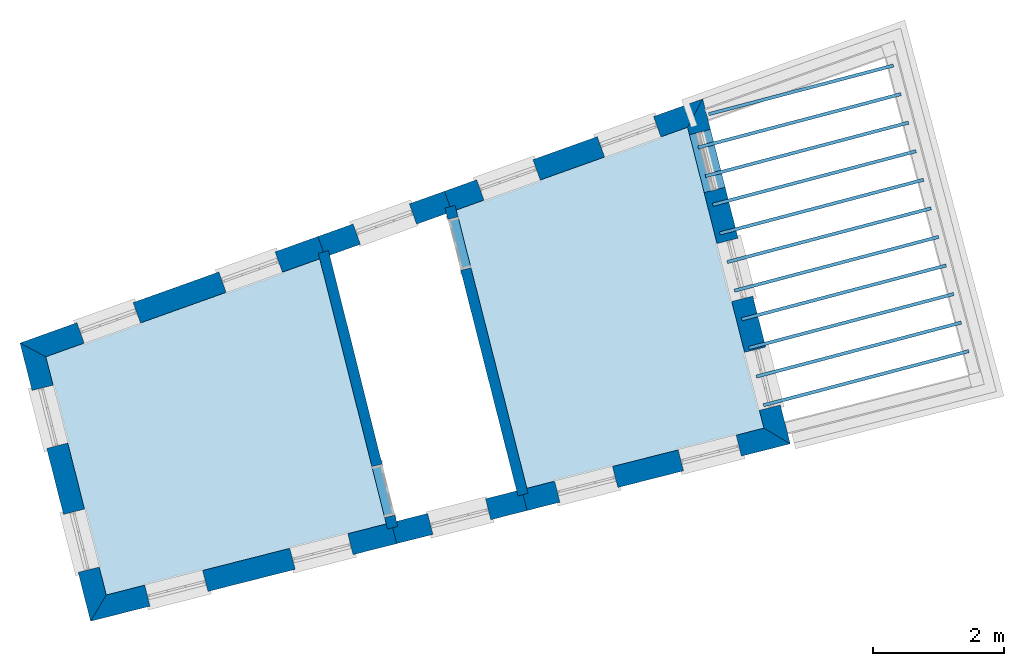
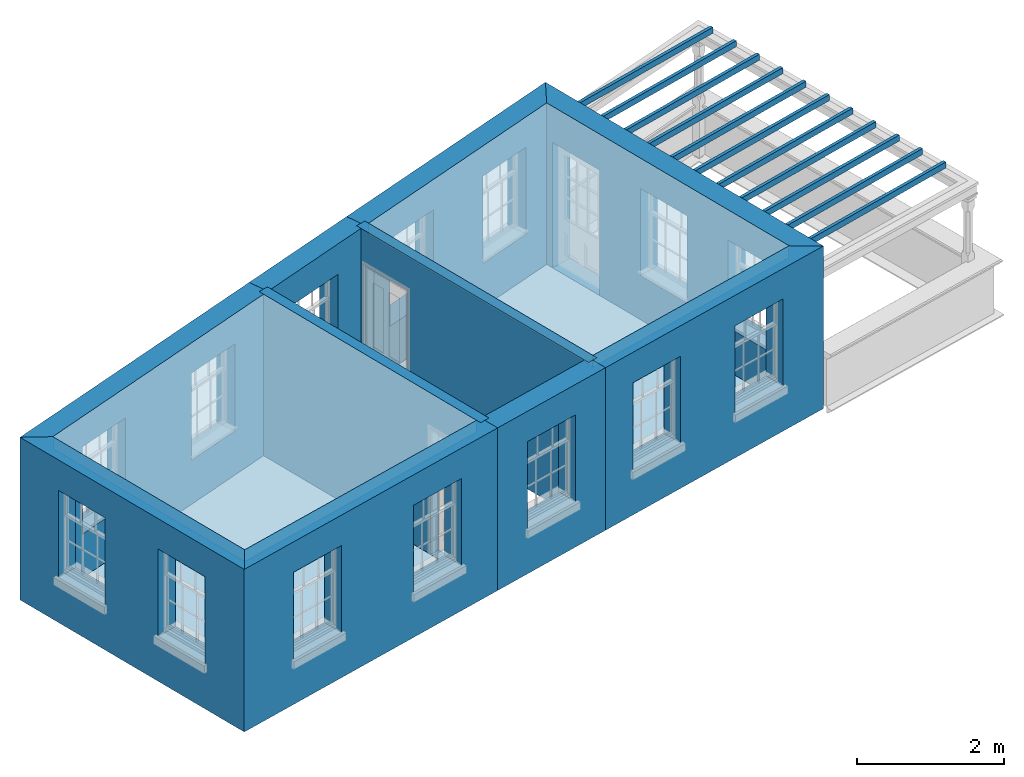
# One storey, part 1 of 10: 15 slabs, 10 walls, 17 openings.
"""IFC2X3 building model written with IfcOpenShell, lengths in metres."""

from ifc_helpers import new_model, si_unit, frame, origin, place, context, subcontext, project, spatial, polyline, outline, extrude, material, layer, layer_set, layer_usage, element, save


model = new_model("IFC2X3")

# Units and contexts
model_context = context("Model", 3, world=origin())
body_context = subcontext(model_context, "Body", "Model", "MODEL_VIEW")
ifc_project = project(units=[si_unit("PLANEANGLEUNIT", "RADIAN"), si_unit("MASSUNIT", "GRAM", prefix="KILO"), si_unit("FORCEUNIT", "NEWTON", prefix="KILO"), si_unit("LENGTHUNIT", "METRE")], contexts=[model_context])

# Site, building, storey
site_placement = place(None, origin())
site = spatial("IfcSite", under=ifc_project, at=site_placement, CompositionType="ELEMENT")
building_placement = place(None, origin())
building = spatial("IfcBuilding", under=site, at=building_placement, Name="Building plot-13", CompositionType="ELEMENT")
storey_placement = place(None, frame((0.0, 0.0, 9.55)))
storey = spatial("IfcBuildingStorey", under=building, at=storey_placement, Name="Floor 2", CompositionType="ELEMENT", Elevation=9.55)

# Slabs
slab_1_placement = place(storey_placement, frame((0.0, 0.0, 2.5)))
element("IfcSlab", 1, at=slab_1_placement, inside=storey, Name="Slab", ObjectType="Slab", PredefinedType="FLOOR", context=body_context, shape_type="SweptSolid", body=[
    extrude(outline(polyline([(72.1588295162765, 49.7758111334306), (73.2338394240791, 45.5372661691658), (76.8445718371103, 46.4530457942866), (75.6822868035305, 51.0356987915879), (72.1588295162765, 49.7758111334306)])), origin(), (0.0, 0.0, 1.0), 0.2),
])
slab_2_placement = place(storey_placement, frame((0.0, 0.0, 2.5)))
element("IfcSlab", 2, at=slab_2_placement, inside=storey, Name="Slab", ObjectType="Slab", PredefinedType="FLOOR", context=body_context, shape_type="SweptSolid", body=[
    extrude(outline(polyline([(66.8267058597151, 43.9122434030099), (71.0924235909926, 44.9941450611672), (70.0791346157294, 49.0321716554071), (65.9065629771408, 47.5401792508866), (66.8267058597151, 43.9122434030099)])), origin(), (0.0, 0.0, 1.0), 0.2),
])
slab_3_placement = place(storey_placement, frame((0.0, 0.0, 2.2)))
element("IfcSlab", 3, at=slab_3_placement, inside=storey, Name="Slab", ObjectType="Slab", PredefinedType="FLOOR", context=body_context, shape_type="SweptSolid", body=[
    extrude(outline(polyline([(79.9713806910682, 47.6019934885122), (79.9586352130492, 47.6503417334655), (76.8322302748347, 46.8261644451892), (76.8449757528537, 46.7778162002358), (79.9713806910682, 47.6019934885122)])), origin(), (0.0, 0.0, 1.0), 0.1),
])
slab_4_placement = place(storey_placement, frame((0.0, 0.0, 2.2)))
element("IfcSlab", 4, at=slab_4_placement, inside=storey, Name="Slab", ObjectType="Slab", PredefinedType="FLOOR", context=body_context, shape_type="SweptSolid", body=[
    extrude(outline(polyline([(79.856671388897, 48.0371276930921), (79.843925910878, 48.0854759380454), (76.7215959859344, 47.2623728974925), (76.7343414639534, 47.2140246525392), (79.856671388897, 48.0371276930921)])), origin(), (0.0, 0.0, 1.0), 0.1),
])
slab_5_placement = place(storey_placement, frame((0.0, 0.0, 2.2)))
element("IfcSlab", 5, at=slab_5_placement, inside=storey, Name="Slab", ObjectType="Slab", PredefinedType="FLOOR", context=body_context, shape_type="SweptSolid", body=[
    extrude(outline(polyline([(79.7419620867259, 48.472261897672), (79.7292166087069, 48.5206101426254), (76.6109616970342, 47.6985813497958), (76.6237071750532, 47.6502331048425), (79.7419620867259, 48.472261897672)])), origin(), (0.0, 0.0, 1.0), 0.1),
])
slab_6_placement = place(storey_placement, frame((0.0, 0.0, 2.2)))
element("IfcSlab", 6, at=slab_6_placement, inside=storey, Name="Slab", ObjectType="Slab", PredefinedType="FLOOR", context=body_context, shape_type="SweptSolid", body=[
    extrude(outline(polyline([(79.6272527845548, 48.907396102252), (79.6145073065358, 48.9557443472053), (76.5003274081339, 48.1347898020991), (76.5130728861529, 48.0864415571458), (79.6272527845548, 48.907396102252)])), origin(), (0.0, 0.0, 1.0), 0.1),
])
slab_7_placement = place(storey_placement, frame((0.0, 0.0, 2.2)))
element("IfcSlab", 7, at=slab_7_placement, inside=storey, Name="Slab", ObjectType="Slab", PredefinedType="FLOOR", context=body_context, shape_type="SweptSolid", body=[
    extrude(outline(polyline([(79.5125434823836, 49.3425303068319), (79.4997980043646, 49.3908785517852), (76.3896931192336, 48.5709982544025), (76.4024385972526, 48.5226500094491), (79.5125434823836, 49.3425303068319)])), origin(), (0.0, 0.0, 1.0), 0.1),
])
slab_8_placement = place(storey_placement, frame((0.0, 0.0, 2.2)))
element("IfcSlab", 8, at=slab_8_placement, inside=storey, Name="Slab", ObjectType="Slab", PredefinedType="FLOOR", context=body_context, shape_type="SweptSolid", body=[
    extrude(outline(polyline([(79.3978341802125, 49.7776645114118), (79.3850887021935, 49.8260127563652), (76.2790588303333, 49.0072067067058), (76.2918043083523, 48.9588584617524), (79.3978341802125, 49.7776645114118)])), origin(), (0.0, 0.0, 1.0), 0.1),
])
slab_9_placement = place(storey_placement, frame((0.0, 0.0, 2.2)))
element("IfcSlab", 9, at=slab_9_placement, inside=storey, Name="Slab", ObjectType="Slab", PredefinedType="FLOOR", context=body_context, shape_type="SweptSolid", body=[
    extrude(outline(polyline([(79.2831248780414, 50.2127987159918), (79.2703794000223, 50.2611469609451), (76.168424541433, 49.4434151590091), (76.1811700194521, 49.3950669140558), (79.2831248780414, 50.2127987159918)])), origin(), (0.0, 0.0, 1.0), 0.1),
])
slab_10_placement = place(storey_placement, frame((0.0, 0.0, 2.2)))
element("IfcSlab", 10, at=slab_10_placement, inside=storey, Name="Slab", ObjectType="Slab", PredefinedType="FLOOR", context=body_context, shape_type="SweptSolid", body=[
    extrude(outline(polyline([(79.1684155758702, 50.6479329205717), (79.1556700978512, 50.696281165525), (76.0577902525328, 49.8796236113124), (76.0705357305518, 49.8312753663591), (79.1684155758702, 50.6479329205717)])), origin(), (0.0, 0.0, 1.0), 0.1),
])
slab_11_placement = place(storey_placement, frame((0.0, 0.0, 2.2)))
element("IfcSlab", 11, at=slab_11_placement, inside=storey, Name="Slab", ObjectType="Slab", PredefinedType="FLOOR", context=body_context, shape_type="SweptSolid", body=[
    extrude(outline(polyline([(79.0537062736991, 51.0830671251516), (79.0409607956801, 51.131415370105), (75.9471559636325, 50.3158320636157), (75.9599014416515, 50.2674838186624), (79.0537062736991, 51.0830671251516)])), origin(), (0.0, 0.0, 1.0), 0.1),
])
slab_12_placement = place(storey_placement, frame((0.0, 0.0, 2.2)))
element("IfcSlab", 12, at=slab_12_placement, inside=storey, Name="Slab", ObjectType="Slab", PredefinedType="FLOOR", context=body_context, shape_type="SweptSolid", body=[
    extrude(outline(polyline([(78.938996971528, 51.5182013297316), (78.9262514935089, 51.5665495746849), (75.8365216747322, 50.7520405159191), (75.8492671527512, 50.7036922709657), (78.938996971528, 51.5182013297316)])), origin(), (0.0, 0.0, 1.0), 0.1),
])
slab_13_placement = place(storey_placement, frame((0.0, 0.0, 2.2)))
element("IfcSlab", 13, at=slab_13_placement, inside=storey, Name="Slab", ObjectType="Slab", PredefinedType="FLOOR", context=body_context, shape_type="SweptSolid", body=[
    extrude(outline(polyline([(78.8242876693568, 51.9533355343115), (78.8115421913378, 52.0016837792648), (75.9977942108907, 51.2599285600122), (76.0105396889098, 51.2115803150588), (78.8242876693568, 51.9533355343115)])), origin(), (0.0, 0.0, 1.0), 0.1),
])
slab_14_placement = place(storey_placement, origin())
element("IfcSlab", 14, at=slab_14_placement, inside=storey, Name="Slab", ObjectType="Slab", PredefinedType="FLOOR", context=body_context, shape_type="SweptSolid", body=[
    extrude(outline(polyline([(72.1588295162765, 49.7758111334306), (73.2338394240791, 45.5372661691658), (76.8445718371103, 46.4530457942866), (75.6822868035305, 51.0356987915879), (72.1588295162765, 49.7758111334306)])), origin(), (0.0, 0.0, 1.0), 0.02),
])
slab_15_placement = place(storey_placement, origin())
element("IfcSlab", 15, at=slab_15_placement, inside=storey, Name="Slab", ObjectType="Slab", PredefinedType="FLOOR", context=body_context, shape_type="SweptSolid", body=[
    extrude(outline(polyline([(66.8267058597151, 43.9122434030099), (71.0924235909926, 44.9941450611672), (70.0791346157294, 49.0321716554071), (65.9065629771408, 47.5401792508866), (66.8267058597151, 43.9122434030099)])), origin(), (0.0, 0.0, 1.0), 0.02),
])

# Wall, openings
ifc_material_1 = material(Name="Masonry")
ifc_layer_1 = layer(ifc_material_1, 0.33, ventilated=False)
ifc_layer_set_1 = layer_set([ifc_layer_1], Name="My Wall")
ifc_layer_usage_1 = layer_usage(ifc_layer_set_1, "AXIS2", "NEGATIVE", 0.08)
wall_1_placement = place(storey_placement, origin())
wall_1 = element("IfcWallStandardCase", 16, at=wall_1_placement, inside=storey, material=ifc_layer_usage_1, Name="exterior", context=body_context, shape_type="SweptSolid", body=[
    extrude(outline(polyline([(73.1562946551384, 45.5175987135619), (73.2374229095042, 45.1977265416814), (77.2455722633567, 46.2143018767719), (76.8445718371103, 46.4530457942866), (73.1562946551384, 45.5175987135619)])), origin(), (0.0, 0.0, 1.0), 2.7),
])
opening_1_placement = place(storey_placement, frame((0.0, 0.0, 0.75)))
element("IfcOpeningElement", 17, at=opening_1_placement, cuts=wall_1, Name="Opening", ObjectType="Opening", context=body_context, shape_type="SweptSolid", body=[
    extrude(outline(polyline([(73.737842523882, 45.3246465220167), (74.6199142705828, 45.5483638295104), (74.5387860162169, 45.8682360013909), (73.6567142695161, 45.6445186938972), (73.737842523882, 45.3246465220167)])), origin(), (0.0, 0.0, 1.0), 1.445),
])
opening_2_placement = place(storey_placement, frame((0.0, 0.0, 0.75)))
element("IfcOpeningElement", 18, at=opening_2_placement, cuts=wall_1, Name="Opening", ObjectType="Opening", context=body_context, shape_type="SweptSolid", body=[
    extrude(outline(polyline([(75.6207534993383, 45.802203790181), (76.5028252460391, 46.0259210976746), (76.4216969916733, 46.3457932695551), (75.5396252449725, 46.1220759620615), (75.6207534993383, 45.802203790181)])), origin(), (0.0, 0.0, 1.0), 1.445),
])

wall_2_placement = place(storey_placement, origin())
wall_2 = element("IfcWallStandardCase", 19, at=wall_2_placement, inside=storey, material=ifc_layer_usage_1, Name="exterior", context=body_context, shape_type="SweptSolid", body=[
    extrude(outline(polyline([(76.8445718371103, 46.4530457942866), (77.2455722633567, 46.2143018767719), (75.9129314952901, 51.4686328142499), (75.6822868035305, 51.0356987915879), (76.8445718371103, 46.4530457942866)])), origin(), (0.0, 0.0, 1.0), 2.7),
])
opening_3_placement = place(storey_placement, frame((0.0, 0.0, 0.75)))
element("IfcOpeningElement", 20, at=opening_3_placement, cuts=wall_2, Name="Opening", ObjectType="Opening", context=body_context, shape_type="SweptSolid", body=[
    extrude(outline(polyline([(77.0953728860989, 46.8065074085449), (76.8716555786053, 47.6885791552457), (76.5517834067248, 47.6074509008799), (76.7755007142184, 46.7253791541791), (77.0953728860989, 46.8065074085449)])), origin(), (0.0, 0.0, 1.0), 1.445),
])
opening_4_placement = place(storey_placement, frame((0.0, 0.0, 0.75)))
element("IfcOpeningElement", 21, at=opening_4_placement, cuts=wall_2, Name="Opening", ObjectType="Opening", context=body_context, shape_type="SweptSolid", body=[
    extrude(outline(polyline([(76.6749810225669, 48.464026844653), (76.4512637150733, 49.3460985913538), (76.1313915431928, 49.264970336988), (76.3551088506864, 48.3828985902872), (76.6749810225669, 48.464026844653)])), origin(), (0.0, 0.0, 1.0), 1.445),
])
opening_5_placement = place(storey_placement, frame((0.0, 0.0, 0.0199999999999996)))
element("IfcOpeningElement", 22, at=opening_5_placement, cuts=wall_2, Name="Opening", ObjectType="Opening", context=body_context, shape_type="SweptSolid", body=[
    extrude(outline(polyline([(76.2545891590349, 50.1215462807611), (76.0308718515412, 51.0036180274619), (75.7109996796607, 50.9224897730961), (75.9347169871544, 50.0404180263953), (76.2545891590349, 50.1215462807611)])), origin(), (0.0, 0.0, 1.0), 2.08),
])

wall_3_placement = place(storey_placement, origin())
wall_3 = element("IfcWallStandardCase", 23, at=wall_3_placement, inside=storey, material=ifc_layer_usage_1, Name="exterior", context=body_context, shape_type="SweptSolid", body=[
    extrude(outline(polyline([(75.6822868035305, 51.0356987915879), (75.9129314952901, 51.4686328142499), (71.9792289491637, 50.0620531725284), (72.090338058868, 49.7513205451126), (75.6822868035305, 51.0356987915879)])), origin(), (0.0, 0.0, 1.0), 2.7),
])
opening_6_placement = place(storey_placement, frame((0.0, 0.0, 0.75)))
element("IfcOpeningElement", 24, at=opening_6_placement, cuts=wall_3, Name="Opening", ObjectType="Opening", context=body_context, shape_type="SweptSolid", body=[
    extrude(outline(polyline([(75.163761942697, 51.2007511865675), (74.3068931822474, 50.894359399201), (74.4180022919517, 50.5836267717852), (75.2748710524013, 50.8900185591517), (75.163761942697, 51.2007511865675)])), origin(), (0.0, 0.0, 1.0), 1.445),
])
opening_7_placement = place(storey_placement, frame((0.0, 0.0, 0.75)))
element("IfcOpeningElement", 25, at=opening_7_placement, cuts=wall_3, Name="Opening", ObjectType="Opening", context=body_context, shape_type="SweptSolid", body=[
    extrude(outline(polyline([(73.326362867158, 50.5437497729969), (72.4694941067084, 50.2373579856305), (72.5806032164127, 49.9266253582147), (73.4374719768623, 50.2330171455811), (73.326362867158, 50.5437497729969)])), origin(), (0.0, 0.0, 1.0), 1.445),
])

# Wall, opening
wall_4_placement = place(storey_placement, origin())
wall_4 = element("IfcWallStandardCase", 26, at=wall_4_placement, inside=storey, material=ifc_layer_usage_1, Name="exterior", context=body_context, shape_type="SweptSolid", body=[
    extrude(outline(polyline([(72.090338058868, 49.7513205451126), (71.9792289491637, 50.0620531725284), (70.0510857180657, 49.3726042415572), (70.16219482777, 49.0618716141414), (72.090338058868, 49.7513205451126)])), origin(), (0.0, 0.0, 1.0), 2.7),
])
opening_8_placement = place(storey_placement, frame((0.0, 0.0, 0.75)))
element("IfcOpeningElement", 27, at=opening_8_placement, cuts=wall_4, Name="Opening", ObjectType="Opening", context=body_context, shape_type="SweptSolid", body=[
    extrude(outline(polyline([(71.4435917138395, 49.870524600726), (70.5867229533899, 49.5641328133596), (70.6978320630942, 49.2534001859438), (71.5547008235438, 49.5597919733102), (71.4435917138395, 49.870524600726)])), origin(), (0.0, 0.0, 1.0), 1.445),
])

# Wall, openings
wall_5_placement = place(storey_placement, origin())
wall_5 = element("IfcWallStandardCase", 28, at=wall_5_placement, inside=storey, material=ifc_layer_usage_1, Name="exterior", context=body_context, shape_type="SweptSolid", body=[
    extrude(outline(polyline([(70.16219482777, 49.0618716141414), (70.0510857180657, 49.3726042415572), (65.5129266056267, 47.7498882014907), (65.9065629771408, 47.5401792508866), (70.16219482777, 49.0618716141414)])), origin(), (0.0, 0.0, 1.0), 2.7),
])
opening_9_placement = place(storey_placement, frame((0.0, 0.0, 0.75)))
element("IfcOpeningElement", 29, at=opening_9_placement, cuts=wall_5, Name="Opening", ObjectType="Opening", context=body_context, shape_type="SweptSolid", body=[
    extrude(outline(polyline([(69.3984892712811, 49.1392543973472), (68.5416205108315, 48.8328626099808), (68.6527296205358, 48.522129982565), (69.5095983809854, 48.8285217699314), (69.3984892712811, 49.1392543973472)])), origin(), (0.0, 0.0, 1.0), 1.445),
])
opening_10_placement = place(storey_placement, frame((0.0, 0.0, 0.75)))
element("IfcOpeningElement", 30, at=opening_10_placement, cuts=wall_5, Name="Opening", ObjectType="Opening", context=body_context, shape_type="SweptSolid", body=[
    extrude(outline(polyline([(67.2364276172623, 48.3661629215608), (66.3795588568127, 48.0597711341944), (66.490667966517, 47.7490385067786), (67.3475367269666, 48.055430294145), (67.2364276172623, 48.3661629215608)])), origin(), (0.0, 0.0, 1.0), 1.445),
])

wall_6_placement = place(storey_placement, origin())
wall_6 = element("IfcWallStandardCase", 31, at=wall_6_placement, inside=storey, material=ifc_layer_usage_1, Name="exterior", context=body_context, shape_type="SweptSolid", body=[
    extrude(outline(polyline([(65.9065629771408, 47.5401792508866), (65.5129266056267, 47.7498882014907), (66.5879619422004, 43.5112429767636), (66.8267058597151, 43.9122434030099), (65.9065629771408, 47.5401792508866)])), origin(), (0.0, 0.0, 1.0), 2.7),
])
opening_11_placement = place(storey_placement, frame((0.0, 0.0, 0.75)))
element("IfcOpeningElement", 32, at=opening_11_placement, cuts=wall_6, Name="Opening", ObjectType="Opening", context=body_context, shape_type="SweptSolid", body=[
    extrude(outline(polyline([(65.6963730633974, 47.0265962074796), (65.920090370891, 46.1445244607788), (66.2399625427715, 46.2256527151446), (66.0162452352779, 47.1077244618454), (65.6963730633974, 47.0265962074796)])), origin(), (0.0, 0.0, 1.0), 1.445),
])
opening_12_placement = place(storey_placement, frame((0.0, 0.0, 0.75)))
element("IfcOpeningElement", 33, at=opening_12_placement, cuts=wall_6, Name="Opening", ObjectType="Opening", context=body_context, shape_type="SweptSolid", body=[
    extrude(outline(polyline([(66.1752193475935, 45.1386029045291), (66.3989366550872, 44.2565311578283), (66.7188088269677, 44.3376594121941), (66.495091519474, 45.2197311588949), (66.1752193475935, 45.1386029045291)])), origin(), (0.0, 0.0, 1.0), 1.445),
])

wall_7_placement = place(storey_placement, origin())
wall_7 = element("IfcWallStandardCase", 34, at=wall_7_placement, inside=storey, material=ifc_layer_usage_1, Name="exterior", context=body_context, shape_type="SweptSolid", body=[
    extrude(outline(polyline([(66.8267058597151, 43.9122434030099), (66.5879619422004, 43.5112429767636), (71.2509007169492, 44.6938906600119), (71.1697724625834, 45.0137628318924), (66.8267058597151, 43.9122434030099)])), origin(), (0.0, 0.0, 1.0), 2.7),
])
opening_13_placement = place(storey_placement, frame((0.0, 0.0, 0.75)))
element("IfcOpeningElement", 35, at=opening_13_placement, cuts=wall_7, Name="Opening", ObjectType="Opening", context=body_context, shape_type="SweptSolid", body=[
    extrude(outline(polyline([(67.494406314742, 43.7411418429004), (68.3764780614428, 43.964859150394), (68.295349807077, 44.2847313222745), (67.4132780603762, 44.0610140147809), (67.494406314742, 43.7411418429004)])), origin(), (0.0, 0.0, 1.0), 1.445),
])
opening_14_placement = place(storey_placement, frame((0.0, 0.0, 0.75)))
element("IfcOpeningElement", 36, at=opening_14_placement, cuts=wall_7, Name="Opening", ObjectType="Opening", context=body_context, shape_type="SweptSolid", body=[
    extrude(outline(polyline([(69.7047120006465, 44.3017352851435), (70.5867837473473, 44.5254525926372), (70.5056554929815, 44.8453247645177), (69.6235837462807, 44.621607457024), (69.7047120006465, 44.3017352851435)])), origin(), (0.0, 0.0, 1.0), 1.445),
])

# Wall, opening
wall_8_placement = place(storey_placement, origin())
wall_8 = element("IfcWallStandardCase", 37, at=wall_8_placement, inside=storey, material=ifc_layer_usage_1, Name="exterior", context=body_context, shape_type="SweptSolid", body=[
    extrude(outline(polyline([(71.1697724625834, 45.0137628318924), (71.2509007169492, 44.6938906600119), (73.2374229095042, 45.1977265416814), (73.1562946551384, 45.5175987135619), (71.1697724625834, 45.0137628318924)])), origin(), (0.0, 0.0, 1.0), 2.7),
])
opening_15_placement = place(storey_placement, frame((0.0, 0.0, 0.75)))
element("IfcOpeningElement", 38, at=opening_15_placement, cuts=wall_8, Name="Opening", ObjectType="Opening", context=body_context, shape_type="SweptSolid", body=[
    extrude(outline(polyline([(71.8031259398763, 44.8339499470999), (72.6851976865771, 45.0576672545935), (72.6040694322113, 45.377539426474), (71.7219976855105, 45.1538221189804), (71.8031259398763, 44.8339499470999)])), origin(), (0.0, 0.0, 1.0), 1.445),
])

ifc_material_2 = material(Name="Masonry")
ifc_layer_2 = layer(ifc_material_2, 0.16, ventilated=False)
ifc_layer_set_2 = layer_set([ifc_layer_2], Name="My Wall")
ifc_layer_usage_2 = layer_usage(ifc_layer_set_2, "AXIS2", "NEGATIVE", 0.08)
wall_9_placement = place(storey_placement, origin())
wall_9 = element("IfcWallStandardCase", 39, at=wall_9_placement, inside=storey, material=ifc_layer_usage_2, Name="interior", context=body_context, shape_type="SweptSolid", body=[
    extrude(outline(polyline([(70.2128535545322, 49.1566719838343), (70.0576650175148, 49.1177294880441), (71.1118456496785, 44.9167468150566), (71.267034186696, 44.9556893108468), (70.2128535545322, 49.1566719838343)])), origin(), (0.0, 0.0, 1.0), 2.7),
])
opening_16_placement = place(storey_placement, frame((0.0, 0.0, 0.0199999999999996)))
element("IfcOpeningElement", 40, at=opening_16_placement, cuts=wall_9, Name="Opening", ObjectType="Opening", context=body_context, shape_type="SweptSolid", body=[
    extrude(outline(polyline([(70.8733228629633, 45.8672766042887), (71.0680353419145, 45.0913339192013), (71.2232238789319, 45.1302764149915), (71.0285113999808, 45.9062191000789), (70.8733228629633, 45.8672766042887)])), origin(), (0.0, 0.0, 1.0), 2.1),
])

wall_10_placement = place(storey_placement, origin())
wall_10 = element("IfcWallStandardCase", 41, at=wall_10_placement, inside=storey, material=ifc_layer_usage_2, Name="interior", context=body_context, shape_type="SweptSolid", body=[
    extrude(outline(polyline([(73.0984173418015, 45.4203864890174), (73.2535068796829, 45.459721400225), (72.1409472860622, 49.8463171225142), (71.9858577481808, 49.8069822113066), (73.0984173418015, 45.4203864890174)])), origin(), (0.0, 0.0, 1.0), 2.7),
])
opening_17_placement = place(storey_placement, frame((0.0, 0.0, 0.0199999999999996)))
element("IfcOpeningElement", 42, at=opening_17_placement, cuts=wall_10, Name="Opening", ObjectType="Opening", context=body_context, shape_type="SweptSolid", body=[
    extrude(outline(polyline([(72.3818736172093, 48.8963937029903), (72.1851990611709, 49.6718413923976), (72.0301095232894, 49.6325064811899), (72.2267840793278, 48.8570587917826), (72.3818736172093, 48.8963937029903)])), origin(), (0.0, 0.0, 1.0), 2.1),
])

save(model, "model.ifc")
